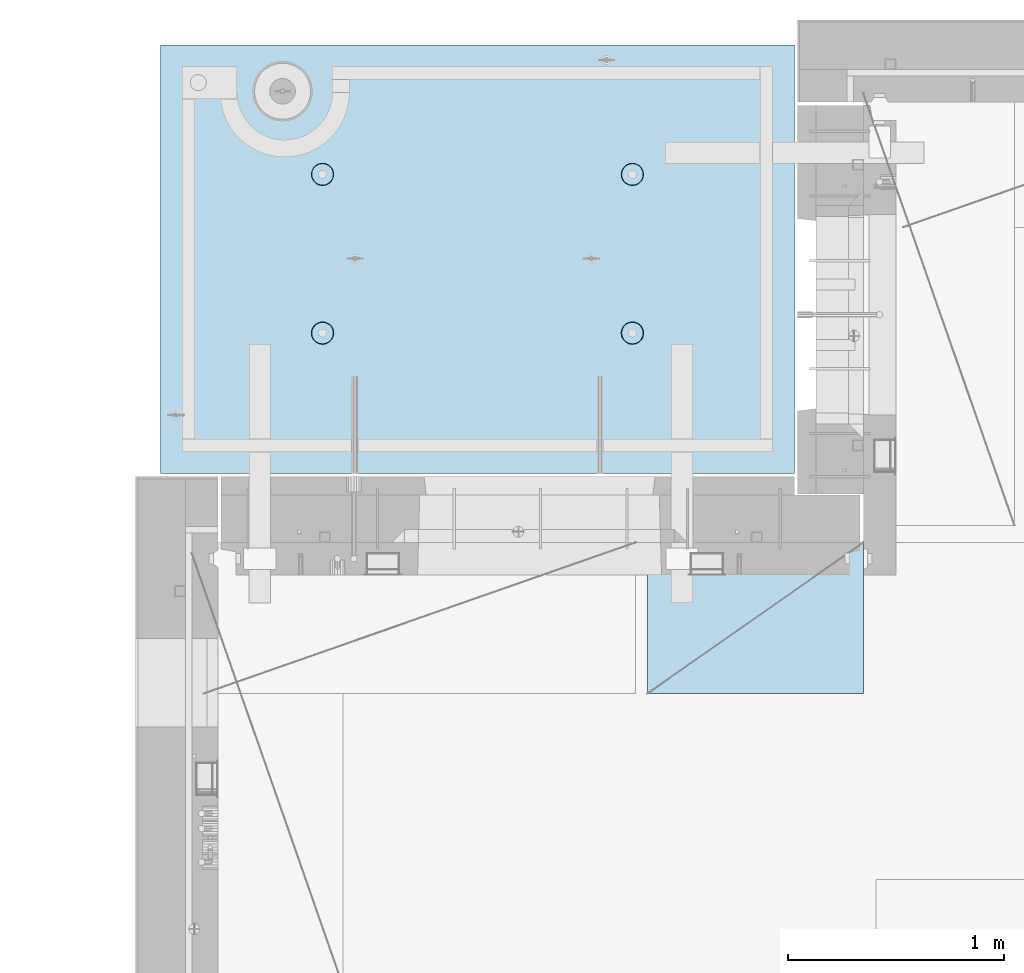
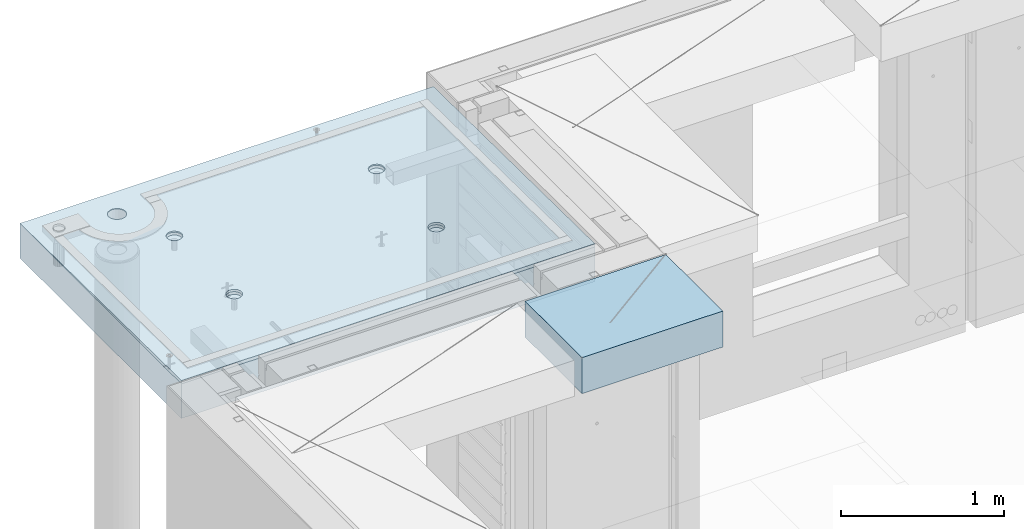
# One storey, part 204 of 352: 2 slabs, 1 plate, 2 elements without a shape of their own.
"""IFC2X3 building model written with IfcOpenShell, lengths in millimetres."""

from ifc_helpers import new_model, si_unit, frame, origin_with_axes, place, context, subcontext, project, spatial, faceted_brep, material, type_object, element, aggregate, save


model = new_model("IFC2X3")

# Units and contexts
model_context = context("Model", 3, precision=1e-05, world=origin_with_axes())
body_context = subcontext(model_context, "Body", "Model", "MODEL_VIEW")
ifc_project = project(units=[si_unit("LENGTHUNIT", "METRE", prefix="MILLI"), si_unit("AREAUNIT", "SQUARE_METRE"), si_unit("VOLUMEUNIT", "CUBIC_METRE"), si_unit("MASSUNIT", "GRAM", prefix="KILO"), si_unit("TIMEUNIT", "SECOND"), si_unit("PLANEANGLEUNIT", "RADIAN"), si_unit("SOLIDANGLEUNIT", "STERADIAN"), si_unit("THERMODYNAMICTEMPERATUREUNIT", "DEGREE_CELSIUS"), si_unit("LUMINOUSINTENSITYUNIT", "LUMEN")], contexts=[model_context])

# Site, building, storey
site_placement = place(None, origin_with_axes())
site = spatial("IfcSite", under=ifc_project, at=site_placement, CompositionType="ELEMENT")
building_placement = place(site_placement, origin_with_axes())
building = spatial("IfcBuilding", under=site, at=building_placement, CompositionType="ELEMENT")
storey_placement = place(building_placement, origin_with_axes())
storey = spatial("IfcBuildingStorey", under=building, at=storey_placement, Name="6", CompositionType="ELEMENT", Elevation=0.0)

# Assembly, slabs
assembly_1_placement = place(storey_placement, origin_with_axes())
assembly_1 = element("IfcElementAssembly", 1, at=assembly_1_placement, inside=storey, AssemblyPlace="NOTDEFINED", PredefinedType="REINFORCEMENT_UNIT")
ifc_material_1 = material(Name="CONCRETE/C35/45")
slab_type_1 = type_object("IfcSlabType", PredefinedType="NOTDEFINED")
slab_1_placement = place(assembly_1_placement, frame((7734.99985681325, 20899.9965573523, 99717.5), z_axis=(0.0, 1.0, 0.0), x_axis=(1.0, 0.0, 0.0)))
slab_1 = element("IfcSlab", 2, at=slab_1_placement, type_object=slab_type_1, material=ifc_material_1, PredefinedType="FLOOR", context=body_context, shape_type="Brep", body=[
    faceted_brep([(209.64691778923, 8.87688398158934, 1795.66138892724), (209.64691778923, 12.5000000975269, 1795.66138892724), (201.519156607756, 12.5000000956934, 1783.49470026561), (201.519156607756, 8.73204270274437, 1783.49470026561), (189.354094229504, 12.5000000940054, 1775.36450517907), (189.354094229504, 8.63525483493868, 1775.36450517907), (175.003751124998, 12.5000000927103, 1772.50855216914), (175.003751124998, 8.60125545370101, 1772.50855216914), (160.652836945715, 12.5000000920118, 1775.36163419229), (160.652836945715, 8.63522065659345, 1775.36163419229), (148.48614828409, 12.5000000919972, 1783.48939537376), (148.48614828409, 8.73197954936768, 1783.48939537376), (140.355953197546, 12.5000000926811, 1795.65445775201), (140.355953197546, 8.87680146773346, 1795.65445775201), (137.500000187611, 12.5000000939617, 1810.00480085652), (137.500000187611, 9.04763858744991, 1810.00480085652), (140.353082210766, 12.5000000956497, 1824.35571503581), (140.353082210766, 9.21848250564653, 1824.35571503581), (148.48084339224, 12.5000000974687, 1836.52240369743), (148.48084339224, 9.36332378449151, 1836.52240369743), (160.645905770492, 12.5000000991568, 1844.65259878397), (160.645905770492, 9.4601116522972, 1844.65259878397), (174.996248874998, 12.5000001004519, 1847.50855179391), (174.996248874998, 9.49411103353486, 1847.50855179391), (189.347163054282, 12.5000001011649, 1844.65546977075), (189.347163054282, 9.46014583064243, 1844.65546977075), (201.513851715907, 12.5000001011795, 1836.52770858928), (201.513851715907, 9.3633869378682, 1836.52770858928), (209.64404680245, 12.500000100481, 1824.36264621103), (209.64404680245, 9.21856501948787, 1824.36264621103), (212.499999812386, 12.5000000992004, 1810.01230310652), (212.499999812386, 9.04772789980052, 1810.01230310652), (0.0, 12.5, 1985.00366210938), (7.41420080885291e-08, 12.4999999999927, 0.0), (-7.41420080885291e-08, -12.5, -3.63797880709171e-12), (0.0, 11.1309547276614, 1985.00366210938), (2935.0, 12.5000004097383, 1985.00366209901), (2935.0, 11.1309547276614, 1985.00366210938), (2935.0, 12.5, 0.0), (2935.0, -12.5, 0.0), (2234.65136896188, -4.56985165992228, 666.133623356985), (2233.6850359994, 12.5000001221924, 665.819642744358), (2236.1904762364, 12.5000001207372, 650.000915653603), (2237.21797072983, -4.76190736876742, 650.000915653603), (2227.22763735012, -4.39666783543362, 680.68109000706), (2226.41396523543, 12.5000001231529, 680.089922611885), (2215.67536748502, -4.25927704213245, 692.221936790684), (2215.08900701139, 12.5000001235312, 691.414880835895), (2201.12537297611, -4.17108941465267, 699.629710429519), (2200.81872714385, 12.5000001232838, 698.685951599829), (2185.00000005312, -4.14070613867079, 702.181910066618), (2185.00000005312, 12.5000001224398, 701.19139183679), (2168.87462713012, -4.17108941465267, 699.629710429519), (2169.18127296234, 12.5000001210865, 698.685951599953), (2154.32463262121, -4.25927704213245, 692.221936790684), (2154.9109930947, 12.5000001193257, 691.414880836099), (2142.77236275611, -4.39666783543362, 680.68109000706), (2143.58603487053, 12.5000001173757, 680.089922612086), (2135.34863114435, -4.56985165992228, 666.133623356985), (2136.31496410644, 12.5000001153967, 665.819642744485), (2132.7820293764, -4.76190736876742, 650.000915653603), (2133.8095238694, 12.5000001135923, 650.000915653603), (2135.3268816397, -4.95404720651277, 633.861141107776), (2136.31496410626, 12.5000001121371, 634.182188562663), (2142.73717131393, -5.12745128343522, 619.29517322078), (2143.58603487023, 12.5000001111621, 619.911908694903), (2154.28944117357, -5.26511432380357, 607.731457644233), (2154.9109930944, 12.5000001107837, 608.586950470697), (2168.85287761663, -5.35352220384812, 600.305182758089), (2169.18127296215, 12.5000001110311, 601.315879706683), (2185.00000005312, -5.38398960883205, 597.745916272124), (2185.00000005312, 12.5000001118751, 598.810439469788), (2201.1471224896, -5.35352220384812, 600.305182758089), (2200.81872714404, 12.500000113243, 601.31587970681), (2215.71055893266, -5.26511432380357, 607.731457644233), (2215.08900701168, 12.5000001149892, 608.586950470901), (2227.2628287923, -5.12745128343522, 619.29517322078), (2226.41396523573, 12.5000001169392, 619.911908695103), (2234.67311846653, -4.95404720651277, 633.861141107776), (2233.68503599959, 12.5000001189328, 634.182188562787), (799.651368961879, -4.56985165992228, 666.133623356985), (798.685036005074, 12.5000000220316, 665.819642746203), (801.190476242367, 12.5000000205619, 650.000915653603), (802.217970729829, -4.76190736876742, 650.000915653603), (792.227637350119, -4.39666783543362, 680.68109000706), (791.41396524025, 12.500000022992, 680.089922615389), (780.675367485019, -4.25927704213245, 692.221936790684), (780.089007014889, 12.5000000233704, 691.414880840719), (766.125372976112, -4.17108941465267, 699.629710429519), (765.818727145695, 12.500000023123, 698.685951605497), (750.000000053116, -4.14070613867079, 702.181910066618), (750.000000053116, 12.500000022279, 701.191391842753), (733.874627130121, -4.17108941465267, 699.629710429519), (734.181272960497, 12.5000000209257, 698.685951605625), (719.324632621214, -4.25927704213245, 692.221936790684), (719.910993091196, 12.5000000191649, 691.414880840923), (707.772362756114, -4.39666783543362, 680.68109000706), (708.586034865702, 12.5000000172149, 680.089922615593), (700.348631144354, -4.56985165992228, 666.133623356985), (701.314964100775, 12.5000000152359, 665.819642746326), (697.782029376403, -4.76190736876742, 650.000915653603), (698.80952386344, 12.5000000134314, 650.000915653603), (700.326881639705, -4.95404720651277, 633.861141107776), (701.314964100589, 12.5000000119617, 634.182188560822), (707.737171313933, -5.12745128343522, 619.29517322078), (708.586034865404, 12.5000000110012, 619.911908691396), (719.289441173572, -5.26511432380357, 607.731457644233), (719.910993090896, 12.5000000106229, 608.586950465873), (733.852877616633, -5.35352220384812, 600.305182758089), (734.181272960313, 12.5000000108703, 601.315879701015), (750.000000053116, -5.38398960883205, 597.745916272124), (750.000000053116, 12.5000000117143, 598.810439463825), (766.1471224896, -5.35352220384812, 600.305182758089), (765.818727145879, 12.5000000130822, 601.315879701138), (780.71055893266, -5.26511432380357, 607.731457644233), (780.089007015189, 12.5000000148284, 608.586950466077), (792.2628287923, -5.12745128343522, 619.29517322078), (791.413965240548, 12.5000000167784, 619.9119086916), (799.673118466528, -4.95404720651277, 633.861141107776), (798.685036005258, 12.500000018772, 634.182188560946), (799.156135017123, 4.17823925742414, 1400.9745431382), (798.685035917459, 12.5000000978907, 1400.82147376184), (801.190476154532, 12.5000000964355, 1385.00274667064), (801.697136924844, 3.98809915517631, 1385.00274667064), (791.806449365287, 4.3496957076859, 1415.37691010137), (791.413965153277, 12.5000000988512, 1415.09175362977), (780.369404424282, 4.48571613449894, 1426.80264589727), (780.089006928914, 12.5000000992295, 1426.4167118541), (765.96453481571, 4.57302415884624, 1434.13653274457), (765.818727060978, 12.5000000989821, 1433.68778261824), (749.999999969796, 4.6031043852272, 1436.66327617152), (749.999999969796, 12.5000000981381, 1436.19322285528), (734.035465123881, 4.57302415884624, 1434.13653274457), (734.181272878572, 12.5000000967848, 1433.68778261837), (719.630595515309, 4.48571613449894, 1426.80264589727), (719.91099301053, 12.5000000950386, 1426.41671185431), (708.193550574304, 4.3496957076859, 1415.37691010137), (708.586034786036, 12.5000000930741, 1415.09175362997), (700.843864922468, 4.17823925742414, 1400.9745431382), (701.314964021747, 12.500000091095, 1400.82147376197), (698.302863014747, 3.98809915517631, 1385.00274667064), (698.809523784634, 12.500000089276, 1385.00274667064), (700.822332352242, 3.79787576314993, 1369.0239538469), (701.314964021563, 12.5000000878208, 1369.18401957925), (708.15871013944, 3.62620125728427, 1354.60327018229), (708.586034785736, 12.5000000868604, 1354.91373971109), (719.595755075041, 3.48991129887872, 1343.15489369192), (719.91099301023, 12.500000086482, 1343.58878148656), (734.013932544907, 3.40238521881111, 1335.80269013289), (734.181272878388, 12.5000000867294, 1336.31771072235), (749.999999969796, 3.37222170254972, 1333.26895034341), (749.999999969796, 12.5000000875589, 1333.81227048538), (765.986067394684, 3.40238521881111, 1335.80269013289), (765.818727061163, 12.5000000889413, 1336.31771072247), (780.40424486455, 3.48991129887872, 1343.15489369192), (780.089006929215, 12.500000090673, 1343.58878148677), (791.841289800152, 3.62620125728427, 1354.60327018229), (791.413965153577, 12.5000000926375, 1354.91373971129), (799.17766758735, 3.79787576314993, 1369.0239538469), (798.685035917644, 12.5000000946166, 1369.18401957938), (2234.15613501712, 4.17823925742414, 1400.9745431382), (2233.68503591179, 12.5000001980516, 1400.82147376), (2236.19047614857, 12.5000001965964, 1385.00274667064), (2236.69713692484, 3.98809915517631, 1385.00274667064), (2226.80644936529, 4.3496957076859, 1415.37691010137), (2226.41396514845, 12.5000001990265, 1415.09175362627), (2215.36940442428, 4.48571613449894, 1426.80264589727), (2215.08900692541, 12.5000001993903, 1426.41671184928), (2200.96453481571, 4.57302415884624, 1434.13653274457), (2200.81872705914, 12.5000001991575, 1433.68778261257), (2184.9999999698, 4.6031043852272, 1436.66327617152), (2184.9999999698, 12.5000001982989, 1436.19322284931), (2169.03546512388, 4.57302415884624, 1434.13653274457), (2169.18127288041, 12.5000001969456, 1433.6877826127), (2154.63059551531, 4.48571613449894, 1426.80264589727), (2154.91099301403, 12.5000001951994, 1426.41671184948), (2143.1935505743, 4.3496957076859, 1415.37691010137), (2143.58603479086, 12.5000001932349, 1415.09175362647), (2135.84386492247, 4.17823925742414, 1400.9745431382), (2136.31496402742, 12.5000001912558, 1400.82147376013), (2133.30286301475, 3.98809915517631, 1385.00274667064), (2133.8095237906, 12.5000001894368, 1385.00274667064), (2135.82233235224, 3.79787576314993, 1369.0239538469), (2136.31496402723, 12.5000001879816, 1369.18401958109), (2143.15871013944, 3.62620125728427, 1354.60327018229), (2143.58603479056, 12.5000001870212, 1354.91373971459), (2154.59575507504, 3.48991129887872, 1343.15489369192), (2154.91099301373, 12.5000001866429, 1343.58878149139), (2169.01393254491, 3.40238521881111, 1335.80269013289), (2169.18127288023, 12.5000001868902, 1336.31771072802), (2184.9999999698, 3.37222170254972, 1333.26895034341), (2184.9999999698, 12.5000001877343, 1333.81227049134), (2200.98606739468, 3.40238521881111, 1335.80269013289), (2200.81872705932, 12.5000001891021, 1336.31771072814), (2215.40424486455, 3.48991129887872, 1343.15489369192), (2215.08900692571, 12.5000001908338, 1343.58878149159), (2226.84128980015, 3.62620125728427, 1354.60327018229), (2226.41396514875, 12.5000001927983, 1354.9137397148), (2234.17766758735, 3.79787576314993, 1369.0239538469), (2233.68503591197, 12.5000001947919, 1369.18401958122), (613.539958053605, 8.15176414522284, 1734.75121634823), (600.266053528658, 7.99374174815603, 1721.47731182328), (583.539958053605, 7.89228512388945, 1712.95494050807), (564.998938391109, 7.85732555369032, 1710.01833148578), (546.457918728613, 7.89228512388945, 1712.95494050807), (529.73182325356, 7.99374174815603, 1721.47731182328), (516.457918728613, 8.15176414522284, 1734.75121634823), (507.935547413399, 8.35088398186781, 1751.47731182328), (504.998938391109, 8.57161002114299, 1770.01833148578), (507.935547413399, 8.79233606038906, 1788.55935114828), (516.457918728613, 8.99145589703403, 1805.28544662333), (529.73182325356, 9.1494782941154, 1818.55935114828), (546.457918728613, 9.25093491838197, 1827.08172246349), (564.998938391109, 9.28589448856656, 1830.01833148578), (583.539958053605, 9.25093491838197, 1827.08172246349), (600.266053528658, 9.1494782941154, 1818.55935114828), (613.539958053605, 8.99145589703403, 1805.28544662333), (622.062329368819, 8.79233606038906, 1788.55935114828), (624.998938391109, 8.57161002114299, 1770.01833148578), (622.062329368819, 8.35088398186781, 1751.47731182328), (613.539958053605, 12.5, 1805.28544662333), (622.062329368819, 12.5, 1788.55935114828), (600.266053528658, 12.5, 1818.55935114828), (583.539958053605, 12.5, 1827.08172246349), (564.998938391109, 12.5, 1830.01833148578), (546.457918728613, 12.5, 1827.08172246349), (529.73182325356, 12.5, 1818.55935114828), (516.457918728613, 12.5, 1805.28544662333), (507.935547413399, 12.5, 1788.55935114828), (504.998938391109, 12.5, 1770.01833148578), (507.935547413399, 12.5, 1751.47731182328), (516.457918728613, 12.5, 1734.75121634823), (529.73182325356, 12.5, 1721.47731182328), (546.457918728613, 12.5, 1712.95494050807), (564.998938391109, 12.5, 1710.01833148578), (583.539958053605, 12.5, 1712.95494050807), (600.266053528658, 12.5, 1721.47731182328), (613.539958053605, 12.5, 1734.75121634823), (622.062329368819, 12.5, 1751.47731182328), (624.998938391109, 12.5, 1770.01833148578)], [[[0, 1, 2, 3]], [[3, 2, 4, 5]], [[5, 4, 6, 7]], [[7, 6, 8, 9]], [[9, 8, 10, 11]], [[11, 10, 12, 13]], [[13, 12, 14, 15]], [[15, 14, 16, 17]], [[17, 16, 18, 19]], [[19, 18, 20, 21]], [[21, 20, 22, 23]], [[23, 22, 24, 25]], [[25, 24, 26, 27]], [[27, 26, 28, 29]], [[29, 28, 30, 31]], [[31, 30, 1, 0]], [[32, 33, 34, 35]], [[36, 32, 35, 37]], [[38, 36, 37, 39]], [[33, 38, 39, 34]], [[40, 41, 42, 43]], [[44, 45, 41, 40]], [[46, 47, 45, 44]], [[48, 49, 47, 46]], [[50, 51, 49, 48]], [[52, 53, 51, 50]], [[53, 52, 54, 55]], [[55, 54, 56, 57]], [[57, 56, 58, 59]], [[59, 58, 60, 61]], [[61, 60, 62, 63]], [[63, 62, 64, 65]], [[65, 64, 66, 67]], [[67, 66, 68, 69]], [[69, 68, 70, 71]], [[72, 73, 71, 70]], [[74, 75, 73, 72]], [[76, 77, 75, 74]], [[78, 79, 77, 76]], [[43, 42, 79, 78]], [[80, 81, 82, 83]], [[84, 85, 81, 80]], [[86, 87, 85, 84]], [[88, 89, 87, 86]], [[90, 91, 89, 88]], [[92, 93, 91, 90]], [[93, 92, 94, 95]], [[95, 94, 96, 97]], [[97, 96, 98, 99]], [[99, 98, 100, 101]], [[101, 100, 102, 103]], [[103, 102, 104, 105]], [[105, 104, 106, 107]], [[107, 106, 108, 109]], [[109, 108, 110, 111]], [[112, 113, 111, 110]], [[114, 115, 113, 112]], [[116, 117, 115, 114]], [[118, 119, 117, 116]], [[83, 82, 119, 118]], [[120, 121, 122, 123]], [[124, 125, 121, 120]], [[126, 127, 125, 124]], [[128, 129, 127, 126]], [[130, 131, 129, 128]], [[132, 133, 131, 130]], [[134, 135, 133, 132]], [[135, 134, 136, 137]], [[137, 136, 138, 139]], [[139, 138, 140, 141]], [[141, 140, 142, 143]], [[143, 142, 144, 145]], [[145, 144, 146, 147]], [[147, 146, 148, 149]], [[149, 148, 150, 151]], [[151, 150, 152, 153]], [[154, 155, 153, 152]], [[156, 157, 155, 154]], [[158, 159, 157, 156]], [[123, 122, 159, 158]], [[160, 161, 162, 163]], [[164, 165, 161, 160]], [[166, 167, 165, 164]], [[168, 169, 167, 166]], [[170, 171, 169, 168]], [[172, 173, 171, 170]], [[174, 175, 173, 172]], [[175, 174, 176, 177]], [[177, 176, 178, 179]], [[179, 178, 180, 181]], [[181, 180, 182, 183]], [[183, 182, 184, 185]], [[185, 184, 186, 187]], [[187, 186, 188, 189]], [[189, 188, 190, 191]], [[191, 190, 192, 193]], [[194, 195, 193, 192]], [[196, 197, 195, 194]], [[198, 199, 197, 196]], [[163, 162, 199, 198]], [[37, 35, 34, 39], [3, 5, 7, 9, 11, 13, 15, 17, 19, 21, 23, 25, 27, 29, 31, 0], [200, 201, 202, 203, 204, 205, 206, 207, 208, 209, 210, 211, 212, 213, 214, 215, 216, 217, 218, 219], [196, 194, 192, 190, 188, 186, 184, 182, 180, 178, 176, 174, 172, 170, 168, 166, 164, 160, 163, 198], [156, 154, 152, 150, 148, 146, 144, 142, 140, 138, 136, 134, 132, 130, 128, 126, 124, 120, 123, 158], [116, 114, 112, 110, 108, 106, 104, 102, 100, 98, 96, 94, 92, 90, 88, 86, 84, 80, 83, 118], [76, 74, 72, 70, 68, 66, 64, 62, 60, 58, 56, 54, 52, 50, 48, 46, 44, 40, 43, 78]], [[216, 220, 221, 217]], [[215, 222, 220, 216]], [[214, 223, 222, 215]], [[213, 224, 223, 214]], [[212, 225, 224, 213]], [[211, 226, 225, 212]], [[210, 227, 226, 211]], [[209, 228, 227, 210]], [[208, 229, 228, 209]], [[207, 230, 229, 208]], [[206, 231, 230, 207]], [[205, 232, 231, 206]], [[204, 233, 232, 205]], [[203, 234, 233, 204]], [[202, 235, 234, 203]], [[201, 236, 235, 202]], [[200, 237, 236, 201]], [[219, 238, 237, 200]], [[218, 239, 238, 219]], [[217, 221, 239, 218]], [[38, 33, 32, 36], [26, 24, 22, 20, 18, 16, 14, 12, 10, 8, 6, 4, 2, 1, 30, 28], [220, 222, 223, 224, 225, 226, 227, 228, 229, 230, 231, 232, 233, 234, 235, 236, 237, 238, 239, 221], [165, 167, 169, 171, 173, 175, 177, 179, 181, 183, 185, 187, 189, 191, 193, 195, 197, 199, 162, 161], [125, 127, 129, 131, 133, 135, 137, 139, 141, 143, 145, 147, 149, 151, 153, 155, 157, 159, 122, 121], [85, 87, 89, 91, 93, 95, 97, 99, 101, 103, 105, 107, 109, 111, 113, 115, 117, 119, 82, 81], [45, 47, 49, 51, 53, 55, 57, 59, 61, 63, 65, 67, 69, 71, 73, 75, 77, 79, 42, 41]]]),
])
slab_type_2 = type_object("IfcSlabType", PredefinedType="NOTDEFINED")
slab_2_placement = place(assembly_1_placement, frame((7734.99985681325, 20899.9965573523, 99575.0), z_axis=(-2.2639999995273e-06, 0.999999999997437, 0.0), x_axis=(0.999999999997251, 2.34499999952812e-06, 0.0)))
slab_2 = element("IfcSlab", 3, at=slab_2_placement, type_object=slab_type_2, material=ifc_material_1, PredefinedType="FLOOR", context=body_context, shape_type="Brep", body=[
    faceted_brep([(2200.45398600256, -110.0, 1337.44476079497), (2214.39241555253, -110.0, 1344.54670420538), (2225.45402859605, -110.0, 1355.60826537005), (2232.55603737762, -110.0, 1369.54666161175), (2235.0032477951, -110.0, 1384.99750559184), (2232.5561098421, -110.0, 1400.44836104917), (2225.45416643169, -110.0, 1414.38679059914), (2214.39260526702, -110.0, 1425.44840364265), (2200.45420902531, -110.0, 1432.55041242422), (2185.00336504523, -110.0, 1434.9976228417), (2169.55250958791, -110.0, 1432.55048488871), (2155.61408003793, -110.0, 1425.44854147829), (2144.55246699442, -110.0, 1414.38698031362), (2137.45045821285, -110.0, 1400.44858407192), (2135.00324779537, -110.0, 1384.99774009184), (2137.45038574836, -110.0, 1369.54688463451), (2144.55232915878, -110.0, 1355.60845508454), (2155.61389032345, -110.0, 1344.54684204102), (2169.55228656515, -110.0, 1337.44483325945), (2185.00313054523, -110.0, 1334.99762284198), (2226.41728354208, -130.0, 1415.08653268859), (2233.68832084322, -130.0, 1400.81623576839), (2215.09235187349, -130.0, 1426.41151747124), (2200.8220890546, -130.0, 1433.68262169999), (2185.0033678369, -130.0, 1436.18809903217), (2169.18463486868, -130.0, 1433.68269588982), (2154.91433794847, -130.0, 1426.41165858869), (2143.58935316583, -130.0, 1415.08672692009), (2136.31824893708, -130.0, 1400.81646410121), (2133.8127716049, -130.0, 1384.9977428835), (2136.31817474725, -130.0, 1369.17900991529), (2143.58921204838, -130.0, 1354.90871299508), (2154.91414371698, -130.0, 1343.58372821243), (2169.18440653586, -130.0, 1336.31262398369), (2185.00312775357, -130.0, 1333.8071466515), (2200.82186072178, -130.0, 1336.31254979386), (2215.09215764199, -130.0, 1343.58358709499), (2226.41714242464, -130.0, 1354.90851876358), (2233.68824665339, -130.0, 1369.17878158247), (2236.19372398557, -130.0, 1384.99750280017), (765.453986006505, -110.0, 1337.44812586997), (779.392415556478, -110.0, 1344.55006928038), (790.454028599992, -110.0, 1355.61163044505), (797.556037381562, -110.0, 1369.55002668675), (800.003247799041, -110.0, 1385.00087066684), (797.556109846048, -110.0, 1400.45172612417), (790.454166435635, -110.0, 1414.39015567414), (779.392605270965, -110.0, 1425.45176871765), (765.45420902926, -110.0, 1432.55377749922), (750.003365049179, -110.0, 1435.0009879167), (734.552509591851, -110.0, 1432.55384996371), (720.614080041878, -110.0, 1425.4519065533), (709.552466998364, -110.0, 1414.39034538862), (702.450458216794, -110.0, 1400.45194914692), (700.003247799315, -110.0, 1385.00110516684), (702.450385752309, -110.0, 1369.5502497095), (709.552329162721, -110.0, 1355.61182015954), (720.613890327391, -110.0, 1344.55020711602), (734.552286569096, -110.0, 1337.44819833446), (750.003130549179, -110.0, 1335.00098791698), (798.688320847163, -130.0, 1400.81960084339), (801.193723989514, -130.0, 1385.00086787517), (791.417283546027, -130.0, 1415.0898977636), (780.092351877434, -130.0, 1426.41488254624), (765.822089058547, -130.0, 1433.68598677499), (750.003367840845, -130.0, 1436.19146410717), (734.184634872629, -130.0, 1433.68606096482), (719.914337952418, -130.0, 1426.41502366369), (708.589353169771, -130.0, 1415.09009199509), (701.318248941023, -130.0, 1400.81982917621), (698.812771608842, -130.0, 1385.00110795851), (701.318174751194, -130.0, 1369.18237499029), (708.589212052329, -130.0, 1354.91207807008), (719.914143720922, -130.0, 1343.58709328743), (734.184406539811, -130.0, 1336.31598905868), (750.003127757513, -130.0, 1333.8105117265), (765.821860725729, -130.0, 1336.31591486885), (780.092157645939, -130.0, 1343.58695216999), (791.417142428585, -130.0, 1354.91188383858), (798.688246657333, -130.0, 1369.18214665747), (2935.0, -130.0, 1.16051523946226e-09), (0.0, -130.0, -3.63797880709171e-12), (0.0, 130.0, -1.81898940354586e-12), (2935.0, 130.0, 1.16051523946226e-09), (2935.00146484375, -130.0, 1985.00366210938), (2935.00146484375, 130.0, 1985.00366210938), (0.00127768016045593, -130.0, 1985.00366210937), (0.00127768016045593, 130.0, 1985.00366210937), (613.544191446293, 130.0, 1805.28400786653), (600.270318048689, 130.0, 1818.55794351875), (583.544242558642, 130.0, 1827.08035405663), (565.003229782545, 130.0, 1830.0170065576), (546.462203233751, 130.0, 1827.08044101401), (529.736087773786, 130.0, 1818.55810892152), (516.462152121568, 130.0, 1805.28423552391), (507.939741583684, 130.0, 1788.55816003387), (505.00308908271, 130.0, 1770.01714725777), (507.939654626302, 130.0, 1751.47612070897), (516.461986718798, 130.0, 1734.75000524901), (529.735860116402, 130.0, 1721.47606959679), (546.461935606448, 130.0, 1712.95365905891), (565.002948382545, 130.0, 1710.01700655793), (583.543974931338, 130.0, 1712.95357210152), (600.270090391306, 130.0, 1721.47590419402), (613.544026043523, 130.0, 1734.74977759163), (622.066436581407, 130.0, 1751.47585308167), (625.003089082381, 130.0, 1770.01686585777), (622.066523538789, 130.0, 1788.55789240656), (622.066523538789, -130.0, 1788.55789240656), (625.003089082381, -130.0, 1770.01686585777), (613.544191446293, -130.0, 1805.28400786653), (600.270318048689, -130.0, 1818.55794351875), (583.544242558642, -130.0, 1827.08035405663), (565.003229782545, -130.0, 1830.0170065576), (546.462203233751, -130.0, 1827.08044101401), (529.736087773786, -130.0, 1818.55810892152), (516.462152121568, -130.0, 1805.28423552391), (507.939741583684, -130.0, 1788.55816003387), (505.00308908271, -130.0, 1770.01714725777), (507.939654626302, -130.0, 1751.47612070897), (516.461986718798, -130.0, 1734.75000524901), (529.735860116402, -130.0, 1721.47606959679), (546.461935606448, -130.0, 1712.95365905891), (565.002948382545, -130.0, 1710.01700655793), (583.543974931338, -130.0, 1712.95357210152), (600.270090391306, -130.0, 1721.47590419402), (613.544026043523, -130.0, 1734.74977759163), (622.066436581407, -130.0, 1751.47585308167), (765.452262510529, -110.0, 602.446294854952), (779.390692060502, -110.0, 609.548238265361), (790.452305104016, -110.0, 620.609799430033), (797.554313885586, -110.0, 634.548195671738), (800.001524303065, -110.0, 649.999039651819), (797.554386350072, -110.0, 665.449895109152), (790.452442939657, -110.0, 679.388324659118), (779.390881774987, -110.0, 690.449937702637), (765.452485533282, -110.0, 697.551946484204), (750.001641553203, -110.0, 699.999156901682), (734.550786095873, -110.0, 697.552018948689), (720.6123565459, -110.0, 690.45007553828), (709.550743502386, -110.0, 679.388514373604), (702.448734720818, -110.0, 665.450118131903), (700.001524303339, -110.0, 649.999274151818), (702.448662256333, -110.0, 634.548418694489), (709.550605666745, -110.0, 620.609989144519), (720.612166831415, -110.0, 609.548376101004), (734.55056307312, -110.0, 602.446367319437), (750.001407053202, -110.0, 599.999156901958), (798.686597351187, -130.0, 665.817769828369), (801.192000493538, -130.0, 649.999036860154), (791.415560050051, -130.0, 680.088066748576), (780.090628381458, -130.0, 691.413051531228), (765.820365562571, -130.0, 698.684155759973), (750.001644344869, -130.0, 701.189633092159), (734.182911376653, -130.0, 698.684229949802), (719.912614456442, -130.0, 691.41319264867), (708.587629673795, -130.0, 680.088260980072), (701.316525445047, -130.0, 665.817998161187), (698.811048112866, -130.0, 649.999276943487), (701.316451255216, -130.0, 634.180543975268), (708.587488556352, -130.0, 619.910247055061), (719.912420224944, -130.0, 608.585262272412), (734.182683043833, -130.0, 601.314158043664), (750.001404261535, -130.0, 598.808680711485), (765.820137229752, -130.0, 601.314083853835), (780.090434149961, -130.0, 608.585121154971), (791.415418932607, -130.0, 619.910052823565), (798.686523161356, -130.0, 634.18031564245), (2200.45226250658, -110.0, 602.442929779951), (2214.39069205656, -110.0, 609.544873190363), (2225.45230510007, -110.0, 620.606434355035), (2232.55431388164, -110.0, 634.544830596737), (2235.00152429912, -110.0, 649.995674576818), (2232.55438634613, -110.0, 665.446530034151), (2225.45244293571, -110.0, 679.38495958412), (2214.39088177104, -110.0, 690.446572627639), (2200.45248552934, -110.0, 697.548581409203), (2185.00164154926, -110.0, 699.995791826681), (2169.55078609193, -110.0, 697.548653873688), (2155.61235654195, -110.0, 690.446710463279), (2144.55074349844, -110.0, 679.385149298603), (2137.44873471687, -110.0, 665.446753056905), (2135.00152429939, -110.0, 649.995909076821), (2137.44866225239, -110.0, 634.545053619491), (2144.5506056628, -110.0, 620.606624069518), (2155.61216682747, -110.0, 609.545011026003), (2169.55056306918, -110.0, 602.443002244436), (2185.00140704926, -110.0, 599.995791826957), (2233.68659734724, -130.0, 665.814404753368), (2236.19200048959, -130.0, 649.995671785153), (2226.41556004611, -130.0, 680.084701673575), (2215.09062837751, -130.0, 691.409686456227), (2200.82036555863, -130.0, 698.680790684972), (2185.00164434092, -130.0, 701.186268017158), (2169.18291137271, -130.0, 698.680864874805), (2154.9126144525, -130.0, 691.409827573672), (2143.58762966985, -130.0, 680.084895905075), (2136.3165254411, -130.0, 665.814633086189), (2133.81104810892, -130.0, 649.995911868486), (2136.31645125127, -130.0, 634.177178900271), (2143.58748855241, -130.0, 619.906881980063), (2154.912420221, -130.0, 608.581897197415), (2169.18268303989, -130.0, 601.310792968667), (2185.00140425759, -130.0, 598.805315636484), (2200.82013722581, -130.0, 601.310718778834), (2215.09043414602, -130.0, 608.58175607997), (2226.41541892866, -130.0, 619.906687748564), (2233.68652315741, -130.0, 634.176950567449)], [[[0, 1, 2, 3, 4, 5, 6, 7, 8, 9, 10, 11, 12, 13, 14, 15, 16, 17, 18, 19]], [[20, 6, 5, 21]], [[22, 7, 6, 20]], [[23, 8, 7, 22]], [[24, 9, 8, 23]], [[25, 10, 9, 24]], [[26, 11, 10, 25]], [[27, 12, 11, 26]], [[28, 13, 12, 27]], [[29, 14, 13, 28]], [[30, 15, 14, 29]], [[31, 16, 15, 30]], [[32, 17, 16, 31]], [[33, 18, 17, 32]], [[34, 19, 18, 33]], [[35, 0, 19, 34]], [[36, 1, 0, 35]], [[37, 2, 1, 36]], [[38, 3, 2, 37]], [[39, 4, 3, 38]], [[21, 5, 4, 39]], [[40, 41, 42, 43, 44, 45, 46, 47, 48, 49, 50, 51, 52, 53, 54, 55, 56, 57, 58, 59]], [[60, 45, 44, 61]], [[62, 46, 45, 60]], [[63, 47, 46, 62]], [[64, 48, 47, 63]], [[65, 49, 48, 64]], [[66, 50, 49, 65]], [[67, 51, 50, 66]], [[68, 52, 51, 67]], [[69, 53, 52, 68]], [[70, 54, 53, 69]], [[71, 55, 54, 70]], [[72, 56, 55, 71]], [[73, 57, 56, 72]], [[74, 58, 57, 73]], [[75, 59, 58, 74]], [[76, 40, 59, 75]], [[77, 41, 40, 76]], [[78, 42, 41, 77]], [[79, 43, 42, 78]], [[61, 44, 43, 79]], [[80, 81, 82, 83]], [[84, 80, 83, 85]], [[86, 84, 85, 87]], [[81, 86, 87, 82]], [[85, 83, 82, 87], [88, 89, 90, 91, 92, 93, 94, 95, 96, 97, 98, 99, 100, 101, 102, 103, 104, 105, 106, 107]], [[108, 107, 106, 109]], [[110, 88, 107, 108]], [[111, 89, 88, 110]], [[112, 90, 89, 111]], [[113, 91, 90, 112]], [[114, 92, 91, 113]], [[115, 93, 92, 114]], [[116, 94, 93, 115]], [[117, 95, 94, 116]], [[118, 96, 95, 117]], [[119, 97, 96, 118]], [[120, 98, 97, 119]], [[121, 99, 98, 120]], [[122, 100, 99, 121]], [[123, 101, 100, 122]], [[124, 102, 101, 123]], [[125, 103, 102, 124]], [[126, 104, 103, 125]], [[127, 105, 104, 126]], [[109, 106, 105, 127]], [[128, 129, 130, 131, 132, 133, 134, 135, 136, 137, 138, 139, 140, 141, 142, 143, 144, 145, 146, 147]], [[148, 133, 132, 149]], [[150, 134, 133, 148]], [[151, 135, 134, 150]], [[152, 136, 135, 151]], [[153, 137, 136, 152]], [[154, 138, 137, 153]], [[155, 139, 138, 154]], [[156, 140, 139, 155]], [[157, 141, 140, 156]], [[158, 142, 141, 157]], [[159, 143, 142, 158]], [[160, 144, 143, 159]], [[161, 145, 144, 160]], [[162, 146, 145, 161]], [[163, 147, 146, 162]], [[164, 128, 147, 163]], [[165, 129, 128, 164]], [[166, 130, 129, 165]], [[167, 131, 130, 166]], [[149, 132, 131, 167]], [[168, 169, 170, 171, 172, 173, 174, 175, 176, 177, 178, 179, 180, 181, 182, 183, 184, 185, 186, 187]], [[188, 173, 172, 189]], [[190, 174, 173, 188]], [[191, 175, 174, 190]], [[192, 176, 175, 191]], [[193, 177, 176, 192]], [[194, 178, 177, 193]], [[195, 179, 178, 194]], [[196, 180, 179, 195]], [[197, 181, 180, 196]], [[198, 182, 181, 197]], [[199, 183, 182, 198]], [[200, 184, 183, 199]], [[201, 185, 184, 200]], [[202, 186, 185, 201]], [[203, 187, 186, 202]], [[204, 168, 187, 203]], [[205, 169, 168, 204]], [[206, 170, 169, 205]], [[207, 171, 170, 206]], [[189, 172, 171, 207]], [[80, 84, 86, 81], [37, 36, 35, 34, 33, 32, 31, 30, 29, 28, 27, 26, 25, 24, 23, 22, 20, 21, 39, 38], [206, 205, 204, 203, 202, 201, 200, 199, 198, 197, 196, 195, 194, 193, 192, 191, 190, 188, 189, 207], [166, 165, 164, 163, 162, 161, 160, 159, 158, 157, 156, 155, 154, 153, 152, 151, 150, 148, 149, 167], [126, 125, 124, 123, 122, 121, 120, 119, 118, 117, 116, 115, 114, 113, 112, 111, 110, 108, 109, 127], [78, 77, 76, 75, 74, 73, 72, 71, 70, 69, 68, 67, 66, 65, 64, 63, 62, 60, 61, 79]]]),
])
aggregate(assembly_1, [slab_1, slab_2])

# Assembly, plate
assembly_2_placement = place(storey_placement, origin_with_axes())
assembly_2 = element("IfcElementAssembly", 4, at=assembly_2_placement, inside=storey, Name="Steel Assembly", AssemblyPlace="NOTDEFINED", PredefinedType="NOTDEFINED")
ifc_material_2 = material()
plate_type = type_object("IfcPlateType", PredefinedType="NOTDEFINED")
plate_placement = place(assembly_2_placement, frame((10990.0, 20580.0000000707, 99595.3), z_axis=(0.0, -1.0, 0.0), x_axis=(-1.0, 3.00000001838171e-08, 0.0)))
plate = element("IfcPlate", 5, at=plate_placement, type_object=plate_type, material=ifc_material_2, Name="RE1_1/2", context=body_context, shape_type="Brep", body=[
    faceted_brep([(1.81898940354586e-12, -135.0, 1.81898940354586e-12), (0.0, -135.0, 699.999999999996), (0.0, 135.0, 699.999999999996), (1.81898940354586e-12, 135.0, 1.81898940354586e-12), (999.99951171875, -135.0, 700.0), (999.99951171875, 135.0, 700.0), (1000.0, -135.0, 0.0), (1000.0, 135.0, 0.0)], [[[0, 1, 2, 3]], [[1, 4, 5, 2]], [[4, 6, 7, 5]], [[6, 0, 3, 7]], [[5, 7, 3, 2]], [[6, 4, 1, 0]]]),
])
aggregate(assembly_2, [plate])

save(model, "model.ifc")
